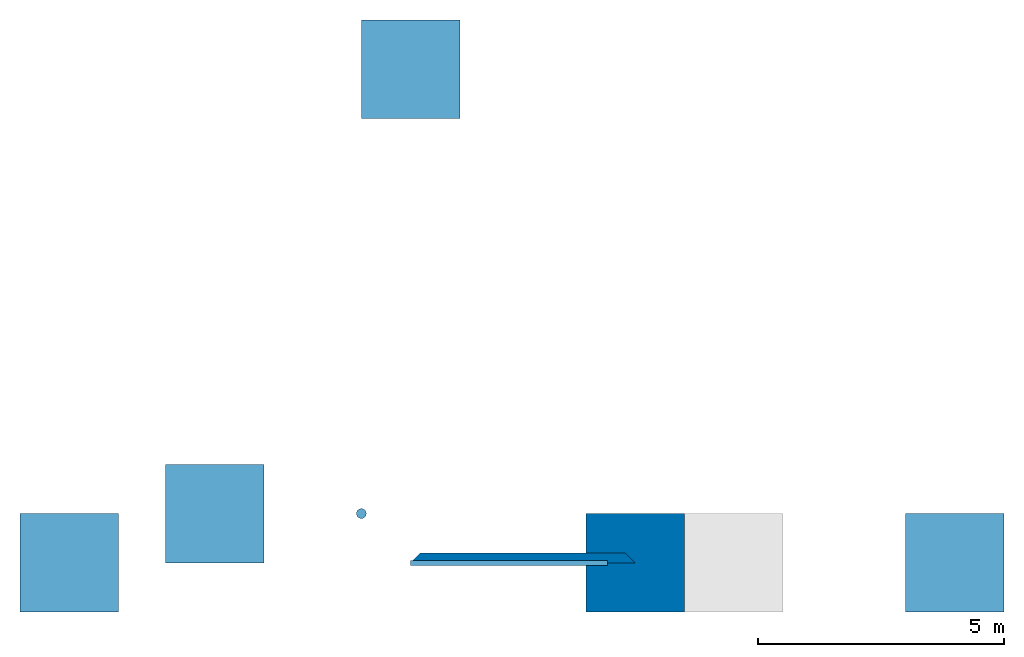
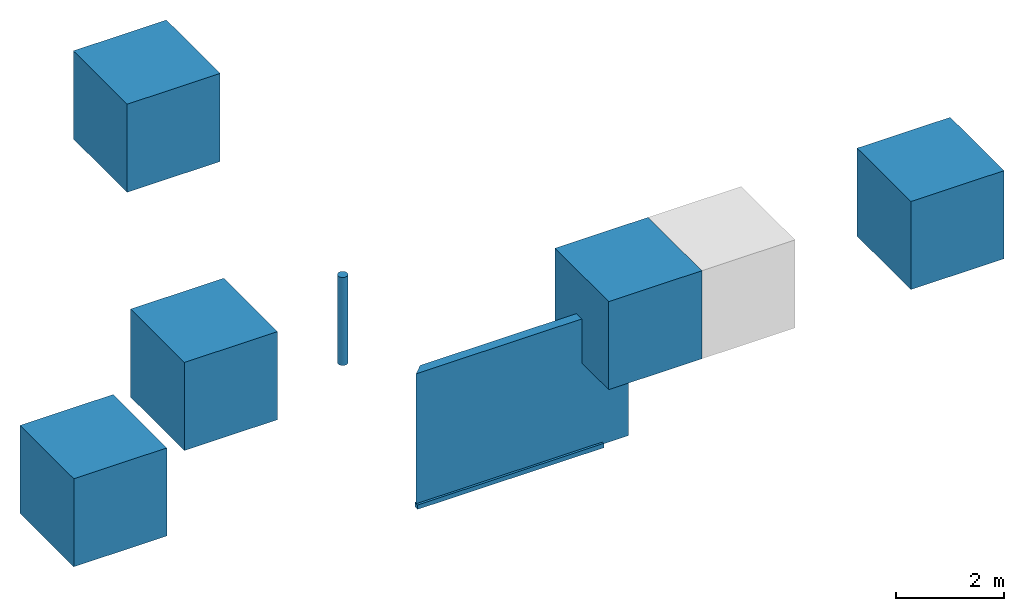
# Not in any storey, part 1 of 2: 6 beams, 2 walls.
"""IFC4 model written with IfcOpenShell, lengths in metres."""

from ifc_helpers import new_model, si_unit, frame, origin_with_axes, place, context, subcontext, project, indexed_curve, rectangle, circle, outline, extrude, clip, halfspace, polygons, source, transform, mapped, material, material_list, layer, layer_set, layer_usage, constituent, constituent_set, material_profile, profile_set, profile_usage, type_object, type_shapes, element, save


model = new_model("IFC4")

# Units and contexts
model_context = context("Model", 3, precision=1e-05)
plan_context = context("Plan", 2, precision=1e-05)
body_context = subcontext(model_context, "Body", "Model", "MODEL_VIEW")
ifc_project = project(units=[si_unit("LENGTHUNIT", "METRE"), si_unit("AREAUNIT", "SQUARE_METRE"), si_unit("VOLUMEUNIT", "CUBIC_METRE")], contexts=[model_context, plan_context])

# Beams
ifc_material_1 = material(Name="Other Material")
ifc_material_profile_1 = material_profile(ifc_material_1, rectangle(XDim=0.100000001490116, YDim=0.100000001490116))
ifc_profile_set_1 = profile_set([ifc_material_profile_1])
ifc_profile_usage_1 = profile_usage(ifc_profile_set_1, cardinal=5)
beam_type = type_object("IfcBeamType", Name="Empty", PredefinedType="BEAM", material=ifc_profile_set_1)
beam_1_placement = place(None, frame((0.0, 0.0, 0.0), z_axis=(1.0, 1.62920699153801e-07, -1.62920684942947e-07), x_axis=(-1.62920684942947e-07, 1.0, 1.19209275339927e-07)))
element("IfcBeam", 1, at=beam_1_placement, type_object=beam_type, material=ifc_profile_usage_1, Name="Beam", PredefinedType="NOTDEFINED", context=body_context, shape_type="SweptSolid", body=[
    extrude(rectangle(XDim=0.100000001490116, YDim=0.100000001490116), origin_with_axes(), (0.0, 0.0, 1.0), 4.00000000000008),
])
ifc_material_profile_2 = material_profile(ifc_material_1, circle(Radius=0.100000001490116))
ifc_profile_set_2 = profile_set([ifc_material_profile_2])
ifc_profile_usage_2 = profile_usage(ifc_profile_set_2)
beam_2_placement = place(None, frame((-1.0, 1.0, 3.0), z_axis=(0.0, 0.0, 1.0), x_axis=(1.0, 0.0, 0.0)))
element("IfcBeam", 2, at=beam_2_placement, material=ifc_profile_usage_2, Name="Cube", PredefinedType="BEAM", context=body_context, shape_type="SweptSolid", body=[
    extrude(circle(Radius=0.100000001490116), origin_with_axes(), (0.0, 0.0, 1.0), 2.0),
])
ifc_layer_1 = layer(ifc_material_1, 0.100000001490116)
ifc_material_2 = material(Name="Material")
ifc_layer_2 = layer(ifc_material_2, 0.100000001490116)
ifc_layer_set_1 = layer_set([ifc_layer_1, ifc_layer_2])
ifc_layer_usage_1 = layer_usage(ifc_layer_set_1, "AXIS2", "POSITIVE", 0.0)
beam_3_placement = place(None, frame((-3.97828102111816, 1.0, 4.0), z_axis=(0.0, 0.0, 1.0), x_axis=(1.0, 0.0, 0.0)))
element("IfcBeam", 3, at=beam_3_placement, material=ifc_layer_usage_1, Name="Cube", PredefinedType="BEAM", context=body_context, shape_type="Tessellation", body=[
    polygons([(-1.0, -1.0, -1.0), (-1.0, -1.0, 1.0), (-1.0, 1.0, -1.0), (-1.0, 1.0, 1.0), (1.0, -1.0, -1.0), (1.0, -1.0, 1.0), (1.0, 1.0, -1.0), (1.0, 1.0, 1.0)], [[[1, 2, 4, 3]], [[3, 4, 8, 7]], [[7, 8, 6, 5]], [[5, 6, 2, 1]], [[3, 7, 5, 1]], [[8, 4, 2, 6]]]),
])
ifc_constituent_1 = constituent(ifc_material_2)
ifc_constituent_2 = constituent(ifc_material_1)
ifc_constituent_set = constituent_set(constituents=[ifc_constituent_1, ifc_constituent_2])
beam_4_placement = place(None, frame((11.0470085144043, 0.0, 3.0), z_axis=(0.0, 0.0, 1.0), x_axis=(1.0, 0.0, 0.0)))
element("IfcBeam", 4, at=beam_4_placement, material=ifc_constituent_set, Name="Cube", PredefinedType="BEAM", context=body_context, shape_type="Tessellation", body=[
    polygons([(-1.0, -1.0, -1.0), (-1.0, -1.0, 1.0), (-1.0, 1.0, -1.0), (-1.0, 1.0, 1.0), (1.0, -1.0, -1.0), (1.0, -1.0, 1.0), (1.0, 1.0, -1.0), (1.0, 1.0, 1.0)], [[[1, 2, 4, 3]], [[3, 4, 8, 7]], [[7, 8, 6, 5]], [[5, 6, 2, 1]], [[3, 7, 5, 1]], [[8, 4, 2, 6]]]),
])
ifc_material_list = material_list([ifc_material_2, ifc_material_1])
beam_5_placement = place(None, frame((-6.93066453933716, 0.0, 3.0), z_axis=(0.0, 0.0, 1.0), x_axis=(1.0, 0.0, 0.0)))
element("IfcBeam", 5, at=beam_5_placement, material=ifc_material_list, Name="Cube", PredefinedType="BEAM", context=body_context, shape_type="Tessellation", body=[
    polygons([(-1.0, -1.0, -1.0), (-1.0, -1.0, 1.0), (-1.0, 1.0, -1.0), (-1.0, 1.0, 1.0), (1.0, -1.0, -1.0), (1.0, -1.0, 1.0), (1.0, 1.0, -1.0), (1.0, 1.0, 1.0)], [[[1, 2, 4, 3]], [[3, 4, 8, 7]], [[7, 8, 6, 5]], [[5, 6, 2, 1]], [[3, 7, 5, 1]], [[8, 4, 2, 6]]]),
])
beam_6_placement = place(None, frame((0.0, 10.0205240249634, 3.0), z_axis=(0.0, 0.0, 1.0), x_axis=(1.0, 0.0, 0.0)))
element("IfcBeam", 6, at=beam_6_placement, material=ifc_material_2, Name="Cube", PredefinedType="BEAM", context=body_context, shape_type="Tessellation", body=[
    polygons([(-1.0, -1.0, -1.0), (-1.0, -1.0, 1.0), (-1.0, 1.0, -1.0), (-1.0, 1.0, 1.0), (1.0, -1.0, -1.0), (1.0, -1.0, 1.0), (1.0, 1.0, -1.0), (1.0, 1.0, 1.0)], [[[1, 2, 4, 3]], [[3, 4, 8, 7]], [[7, 8, 6, 5]], [[5, 6, 2, 1]], [[3, 7, 5, 1]], [[8, 4, 2, 6]]]),
])

# Walls
ifc_layer_3 = layer(ifc_material_2, 0.1)
ifc_layer_4 = layer(ifc_material_1, 0.100000001490116)
ifc_layer_set_2 = layer_set([ifc_layer_3, ifc_layer_4], Name="brick")
ifc_layer_usage_2 = layer_usage(ifc_layer_set_2, "AXIS2", "POSITIVE", 0.0)
wall_type_1 = type_object("IfcWallType", Name="DEMO100", material=ifc_layer_set_2)
wall_1_placement = place(None, origin_with_axes())
element("IfcWall", 7, at=wall_1_placement, type_object=wall_type_1, material=ifc_layer_usage_2, Name="Wall", context=body_context, shape_type="Clipping", body=[
    clip(clip(extrude(outline(indexed_curve([(0.0, 0.0), (0.0, 0.200000001490116), (4.55830755046315, 0.200000001490116), (4.55830755046315, 0.0), (0.0, 0.0)], self_intersect=False)), origin_with_axes(), (0.0, 0.0, 1.0), 3.0), halfspace(frame((0.0, 0.0, 0.0), z_axis=(-0.707106828689575, 0.70710676908493, 0.0), x_axis=(-0.70710676908493, -0.707106828689575, 0.0)), False)), halfspace(frame((4.55830764770508, 0.0, 0.0), z_axis=(0.707107126712799, 0.707106411457062, 0.0), x_axis=(0.707106411457062, -0.707107126712799, 0.0)), False)),
])
wall_type_2 = type_object("IfcWallType", Name="Cube", PredefinedType="ELEMENTEDWALL", material=ifc_material_1)
shared_shape = source(origin_with_axes(), body_context, "Body", "Tessellation", [
    polygons([(-1.0, -1.0, -1.0), (-1.0, -1.0, 1.0), (-1.0, 1.0, -1.0), (-1.0, 1.0, 1.0), (1.0, -1.0, -1.0), (1.0, -1.0, 1.0), (1.0, 1.0, -1.0), (1.0, 1.0, 1.0)], [[[1, 2, 4, 3]], [[3, 4, 8, 7]], [[7, 8, 6, 5]], [[5, 6, 2, 1]], [[3, 7, 5, 1]], [[8, 4, 2, 6]]]),
])
type_shapes(wall_type_2, [shared_shape])
wall_2_placement = place(None, frame((4.55830860137939, 0.0, 3.0), z_axis=(0.0, 0.0, 1.0), x_axis=(1.0, 0.0, 0.0)))
element("IfcWall", 8, at=wall_2_placement, type_object=wall_type_2, Name="Wall", context=body_context, shape_type="MappedRepresentation", body=[
    mapped(shared_shape, transform((0.0, 0.0, 0.0), x_axis=(1.0, 0.0, 0.0), y_axis=(0.0, 1.0, 0.0), z_axis=(0.0, 0.0, 1.0), scale=1.0)),
])

save(model, "model.ifc")
